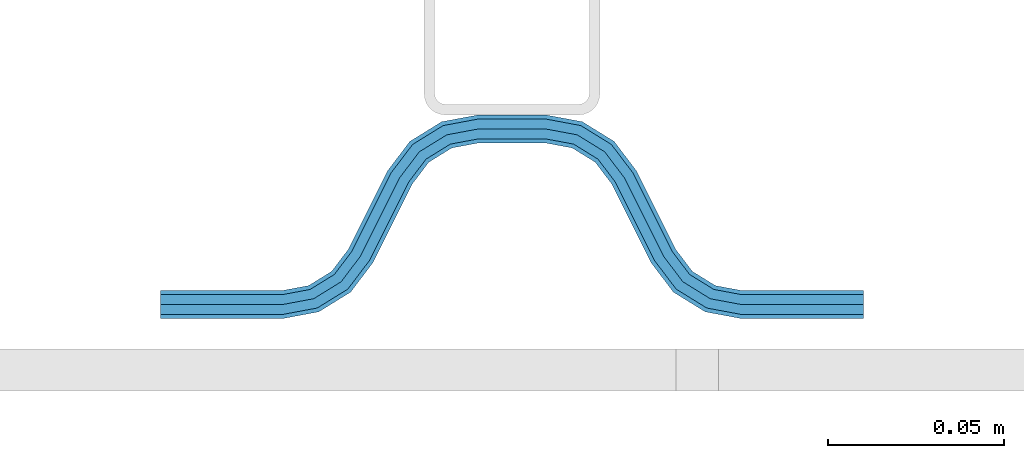
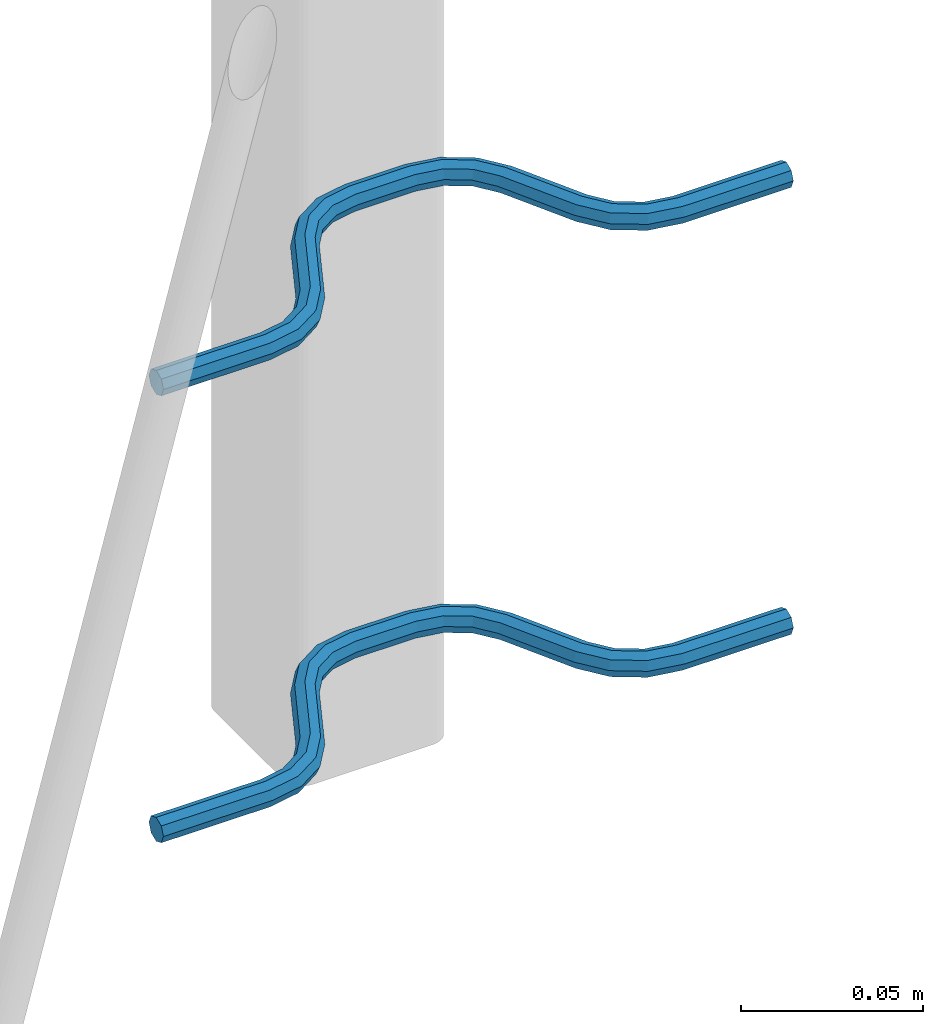
# One storey, part 4 of 5: 2 beams, 2 elements without a shape of their own.
"""IFC2X3 building model written with IfcOpenShell, lengths in millimetres."""

from ifc_helpers import new_model, si_unit, frame, origin_with_axes, place, context, subcontext, project, spatial, faceted_brep, material, type_object, element, aggregate, save


model = new_model("IFC2X3")

# Units and contexts
model_context = context("Model", 3, precision=1e-05, world=origin_with_axes())
body_context = subcontext(model_context, "Body", "Model", "MODEL_VIEW")
ifc_project = project(units=[si_unit("LENGTHUNIT", "METRE", prefix="MILLI"), si_unit("AREAUNIT", "SQUARE_METRE"), si_unit("VOLUMEUNIT", "CUBIC_METRE"), si_unit("MASSUNIT", "GRAM", prefix="KILO"), si_unit("TIMEUNIT", "SECOND"), si_unit("PLANEANGLEUNIT", "RADIAN"), si_unit("SOLIDANGLEUNIT", "STERADIAN"), si_unit("THERMODYNAMICTEMPERATUREUNIT", "DEGREE_CELSIUS"), si_unit("LUMINOUSINTENSITYUNIT", "LUMEN")], contexts=[model_context])

# Site, building, storey
site_placement = place(None, origin_with_axes())
site = spatial("IfcSite", under=ifc_project, at=site_placement, CompositionType="ELEMENT")
building_placement = place(site_placement, origin_with_axes())
building = spatial("IfcBuilding", under=site, at=building_placement, Name="Undefined", CompositionType="ELEMENT")
storey_placement = place(building_placement, origin_with_axes())
storey = spatial("IfcBuildingStorey", under=building, at=storey_placement, Name="Undefined", CompositionType="ELEMENT", Elevation=0.0)

# Assembly, beam
assembly_1_placement = place(storey_placement, origin_with_axes())
assembly_1 = element("IfcElementAssembly", 1, at=assembly_1_placement, inside=storey, Name="Steel Assembly", AssemblyPlace="NOTDEFINED", PredefinedType="NOTDEFINED")
ifc_material = material(Name="REBAR/A500HW")
beam_type = type_object("IfcBeamType", Name="D8", PredefinedType="NOTDEFINED")
beam_1_placement = place(assembly_1_placement, frame((36820.0028955971, 6595.97468822386, 2430.99992151562), z_axis=(0.0, 0.0, 1.0), x_axis=(-0.999999999544916, 3.01689999841786e-05, 0.0)))
beam_1 = element("IfcBeam", 2, at=beam_1_placement, type_object=beam_type, material=ifc_material, Name="AnchorRebar", ObjectType="D8", context=body_context, shape_type="Brep", body=[
    faceted_brep([(2.18278728425503e-11, -4.0, 0.0), (1.45519152283669e-11, -2.82842712474576, -2.82842712474621), (34.5491497807598, -2.82842712464117, -2.82842712474621), (34.5491497803741, -3.99999999989996, 0.0), (7.27595761418343e-12, 9.09494701772928e-13, -4.0), (34.5491497807452, 1.04591890703887e-10, -4.0), (-7.27595761418343e-12, 2.82842712474667, -2.82842712474621), (34.5491497807379, 2.82842712485035, -2.82842712474621), (-1.45519152283669e-11, 4.00000000000091, 0.0), (34.5491497807307, 4.00000000010459, 0.0), (-7.27595761418343e-12, 2.82842712474667, 2.82842712474621), (34.5491497807379, 2.82842712485035, 2.82842712474621), (7.27595761418343e-12, 9.09494701772928e-13, 4.0), (34.5491497807452, 1.04591890703887e-10, 4.0), (1.45519152283669e-11, -2.82842712474576, 2.82842712474621), (34.5491497807598, -2.82842712464117, 2.82842712474621), (45.0102956729461, 2.04744769146328, 0.0), (44.5876751635806, 0.954756103187719, -2.82842712474621), (43.5673789981374, -1.68323474873705, -4.0), (42.5470828327016, -4.32122560064909, -2.82842712474621), (42.1244623233288, -5.41391718892919, 0.0), (42.5470828327016, -4.32122560064909, 2.82842712474621), (43.5673789981374, -1.68323474873705, 4.0), (44.5876751635806, 0.954756103187719, 2.82842712474621), (53.2744249666721, -4.41395070840099, 2.82842712474621), (54.0627564232709, -3.54728092319965, 0.0), (51.3712244725102, -6.5062766579249, 4.0), (49.4680239783702, -8.5986026074479, 2.82842712474621), (48.6796925217786, -9.46527239263742, 0.0), (49.4680239783702, -8.5986026074479, -2.82842712474621), (51.3712244725102, -6.5062766579249, -4.0), (53.2744249666721, -4.41395070840099, -2.82842712474621), (59.4396520595255, -12.5547498008955, 2.82842712474621), (60.4875387112043, -12.0308065146473, 0.0), (56.9098298931422, -13.8196607884638, 4.0), (54.3800077267733, -15.0845717760394, 2.82842712474621), (53.3321210758877, -15.6085150625322, 0.0), (54.3800077267733, -15.0845717760394, -2.82842712474621), (56.9098298931422, -13.8196607884638, -4.0), (59.4396520595255, -12.5547498008955, -2.82842712474621), (65.5603461600695, -37.4452503321118, -2.82842712474621), (64.5124595074303, -37.9691936178024, 0.0), (68.0901683264674, -36.1803393445653, -4.0), (70.6199904928581, -34.9154283570169, -2.82842712474621), (71.6678771445659, -34.3914850707815, 0.0), (70.6199904928581, -34.9154283570169, 2.82842712474621), (68.0901683264674, -36.1803393445653, 4.0), (65.5603461600695, -37.4452503321118, 2.82842712474621), (76.3203054721744, -40.5347275358363, 0.0), (75.53197400301, -41.4013973095998, -2.82842712474621), (73.6287734785365, -43.4937232315178, -4.0), (71.7255729540339, -45.5860491534368, -2.82842712474621), (70.9372414848622, -46.4527189272021, 0.0), (71.7255729540339, -45.5860491534368, 2.82842712474621), (73.6287734785365, -43.4937232315178, 4.0), (75.53197400301, -41.4013973095998, 2.82842712474621), (82.4529147876528, -45.6787743011646, 2.82842712474621), (82.8755353286688, -44.5860827251363, 0.0), (81.4326185457539, -48.3167651235117, 4.0), (80.4123223038914, -50.9547559458606, 2.82842712474621), (79.9897017628609, -52.0474475218944, 0.0), (80.4123223038914, -50.9547559458606, -2.82842712474621), (81.4326185457539, -48.3167651235117, -4.0), (82.4529147876528, -45.6787743011646, -2.82842712474621), (90.4508474762042, -47.1715730090009, 2.82842712474621), (90.450847527085, -46.0000001337467, 0.0), (90.4508473533715, -50.0000001337448, 4.0), (90.4508472305388, -52.8284272584888, 2.82842712474621), (90.4508471810695, -54.0000001334174, 0.0), (90.4508472305388, -52.8284272584888, -2.82842712474621), (90.4508473533715, -50.0000001337448, -4.0), (90.4508474762042, -47.1715730090009, -2.82842712474621), (109.549147671336, -52.8284280870112, -2.82842712474621), (109.549147618905, -54.0000009615069, 0.0), (109.549147794081, -50.0000009622636, -4.0), (109.549147916834, -47.1715738375178, -2.82842712474621), (109.549147967678, -46.0000009622645, 0.0), (109.549147916834, -47.1715738375178, 2.82842712474621), (109.549147794081, -50.0000009622636, 4.0), (109.549147671336, -52.8284280870112, 2.82842712474621), (120.010293517997, -52.0474491371906, 0.0), (119.587673059228, -50.9547575293454, 2.82842712474621), (118.567377015977, -48.3167666302043, 4.0), (117.547080972698, -45.6787757310603, 2.82842712474621), (117.124460513915, -44.5860841232243, 0.0), (117.547080972698, -45.6787757310603, -2.82842712474621), (118.567377015977, -48.3167666302043, -4.0), (119.587673059228, -50.9547575293454, -2.82842712474621), (128.274423051233, -45.586051174274, -2.82842712474621), (129.062754465187, -46.4527209982516, 0.0), (126.371222660055, -43.4937251311139, -4.0), (124.468022268862, -41.4013990879685, -2.82842712474621), (123.679690854915, -40.5347292639935, 0.0), (124.468022268862, -41.4013990879685, 2.82842712474621), (126.371222660055, -43.4937251311139, 4.0), (128.274423051233, -45.586051174274, 2.82842712474621), (134.439650508568, -37.4452524573453, -2.82842712474621), (135.48753713489, -37.9691957980858, 0.0), (131.909828408126, -36.1803413379666, -4.0), (129.380006307663, -34.9154302185971, -2.82842712474621), (128.332119683255, -34.3914868777574, 0.0), (129.380006307663, -34.9154302185971, 2.82842712474621), (131.909828408126, -36.1803413379666, 4.0), (134.439650508568, -37.4452524573453, 2.82842712474621), (145.619991978041, -15.0845707426524, -2.82842712474621), (146.66787860055, -15.6085140834621, 0.0), (143.09016987752, -13.8196596233502, -4.0), (140.560347777006, -12.5547485040488, -2.82842712474621), (139.512461152583, -12.0308051632373, 0.0), (140.560347777006, -12.5547485040488, 2.82842712474621), (143.09016987752, -13.8196596233502, 4.0), (145.619991978041, -15.0845707426524, 2.82842712474621), (151.32030720418, -9.46527190098914, 0.0), (150.531975777645, -8.59860208845657, 2.82842712474621), (148.628775356075, -6.50627607293518, 4.0), (146.725574934491, -4.41395005741106, 2.82842712474621), (145.937243507949, -3.5472802448794, 0.0), (146.725574934491, -4.41395005741106, -2.82842712474621), (148.628775356075, -6.50627607293518, -4.0), (150.531975777645, -8.59860208845657, -2.82842712474621), (157.452916713031, -4.32122546032224, -2.82842712474621), (157.875537203472, -5.41391705590922, 0.0), (156.432620593252, -1.68323459075145, -4.0), (155.412324473487, 0.954756278815694, -2.82842712474621), (154.989703983039, 2.04744787441086, 0.0), (155.412324473487, 0.954756278815694, 2.82842712474621), (156.432620593252, -1.68323459075145, 4.0), (157.452916713031, -4.32122546032224, 2.82842712474621), (165.450849406719, -2.82842712265665, -2.82842712474621), (165.4508494084, -3.99999999905958, 0.0), (165.450849406632, 2.07910488825291e-09, -4.0), (165.45084940653, 2.82842712682032, -2.82842712474621), (165.450849406501, 4.00000000206637, 0.0), (165.45084940653, 2.82842712682032, 2.82842712474621), (165.450849406632, 2.07910488825291e-09, 4.0), (165.450849406719, -2.82842712265665, 2.82842712474621), (200.00000008905, -2.8284271237826, -2.82842712474621), (200.00000008905, -3.99999999903685, 0.0), (200.00000008905, 9.64064383879304e-10, -4.0), (200.00000008905, 2.82842712570982, -2.82842712474621), (200.00000008905, 4.00000000096315, 0.0), (200.00000008905, 2.82842712570982, 2.82842712474621), (200.00000008905, 9.64064383879304e-10, 4.0), (200.00000008905, -2.8284271237826, 2.82842712474621)], [[[0, 1, 2, 3]], [[1, 4, 5, 2]], [[4, 6, 7, 5]], [[6, 8, 9, 7]], [[8, 10, 11, 9]], [[10, 12, 13, 11]], [[12, 14, 15, 13]], [[14, 0, 3, 15]], [[14, 12, 10, 8, 6, 4, 1, 0]], [[7, 9, 16, 17]], [[5, 7, 17, 18]], [[2, 5, 18, 19]], [[3, 2, 19, 20]], [[15, 3, 20, 21]], [[13, 15, 21, 22]], [[11, 13, 22, 23]], [[9, 11, 23, 16]], [[23, 24, 25, 16]], [[22, 26, 24, 23]], [[21, 27, 26, 22]], [[20, 28, 27, 21]], [[19, 29, 28, 20]], [[18, 30, 29, 19]], [[17, 31, 30, 18]], [[16, 25, 31, 17]], [[24, 32, 33, 25]], [[26, 34, 32, 24]], [[27, 35, 34, 26]], [[28, 36, 35, 27]], [[29, 37, 36, 28]], [[30, 38, 37, 29]], [[31, 39, 38, 30]], [[25, 33, 39, 31]], [[36, 37, 40, 41]], [[37, 38, 42, 40]], [[38, 39, 43, 42]], [[39, 33, 44, 43]], [[33, 32, 45, 44]], [[32, 34, 46, 45]], [[34, 35, 47, 46]], [[35, 36, 41, 47]], [[43, 44, 48, 49]], [[42, 43, 49, 50]], [[40, 42, 50, 51]], [[41, 40, 51, 52]], [[47, 41, 52, 53]], [[46, 47, 53, 54]], [[45, 46, 54, 55]], [[44, 45, 55, 48]], [[55, 56, 57, 48]], [[54, 58, 56, 55]], [[53, 59, 58, 54]], [[52, 60, 59, 53]], [[51, 61, 60, 52]], [[50, 62, 61, 51]], [[49, 63, 62, 50]], [[48, 57, 63, 49]], [[56, 64, 65, 57]], [[58, 66, 64, 56]], [[59, 67, 66, 58]], [[60, 68, 67, 59]], [[61, 69, 68, 60]], [[62, 70, 69, 61]], [[63, 71, 70, 62]], [[57, 65, 71, 63]], [[68, 69, 72, 73]], [[69, 70, 74, 72]], [[70, 71, 75, 74]], [[71, 65, 76, 75]], [[65, 64, 77, 76]], [[64, 66, 78, 77]], [[66, 67, 79, 78]], [[67, 68, 73, 79]], [[79, 73, 80, 81]], [[78, 79, 81, 82]], [[77, 78, 82, 83]], [[76, 77, 83, 84]], [[75, 76, 84, 85]], [[74, 75, 85, 86]], [[72, 74, 86, 87]], [[73, 72, 87, 80]], [[87, 88, 89, 80]], [[86, 90, 88, 87]], [[85, 91, 90, 86]], [[84, 92, 91, 85]], [[83, 93, 92, 84]], [[82, 94, 93, 83]], [[81, 95, 94, 82]], [[80, 89, 95, 81]], [[88, 96, 97, 89]], [[90, 98, 96, 88]], [[91, 99, 98, 90]], [[92, 100, 99, 91]], [[93, 101, 100, 92]], [[94, 102, 101, 93]], [[95, 103, 102, 94]], [[89, 97, 103, 95]], [[97, 96, 104, 105]], [[96, 98, 106, 104]], [[98, 99, 107, 106]], [[99, 100, 108, 107]], [[100, 101, 109, 108]], [[101, 102, 110, 109]], [[102, 103, 111, 110]], [[103, 97, 105, 111]], [[111, 105, 112, 113]], [[110, 111, 113, 114]], [[109, 110, 114, 115]], [[108, 109, 115, 116]], [[107, 108, 116, 117]], [[106, 107, 117, 118]], [[104, 106, 118, 119]], [[105, 104, 119, 112]], [[119, 120, 121, 112]], [[118, 122, 120, 119]], [[117, 123, 122, 118]], [[116, 124, 123, 117]], [[115, 125, 124, 116]], [[114, 126, 125, 115]], [[113, 127, 126, 114]], [[112, 121, 127, 113]], [[120, 128, 129, 121]], [[122, 130, 128, 120]], [[123, 131, 130, 122]], [[124, 132, 131, 123]], [[125, 133, 132, 124]], [[126, 134, 133, 125]], [[127, 135, 134, 126]], [[121, 129, 135, 127]], [[129, 128, 136, 137]], [[128, 130, 138, 136]], [[130, 131, 139, 138]], [[131, 132, 140, 139]], [[132, 133, 141, 140]], [[133, 134, 142, 141]], [[134, 135, 143, 142]], [[135, 129, 137, 143]], [[138, 139, 140, 141, 142, 143, 137, 136]]]),
])
aggregate(assembly_1, [beam_1])

assembly_2_placement = place(storey_placement, origin_with_axes())
assembly_2 = element("IfcElementAssembly", 3, at=assembly_2_placement, inside=storey, Name="Steel Assembly", AssemblyPlace="NOTDEFINED", PredefinedType="NOTDEFINED")
beam_2_placement = place(assembly_2_placement, frame((36820.0028955971, 6595.97468822386, 2580.99992151562), z_axis=(0.0, 0.0, 1.0), x_axis=(-0.999999999544916, 3.01689999841786e-05, 0.0)))
beam_2 = element("IfcBeam", 4, at=beam_2_placement, type_object=beam_type, material=ifc_material, Name="AnchorRebar", ObjectType="D8", context=body_context, shape_type="Brep", body=[
    faceted_brep([(2.18278728425503e-11, -4.0, 0.0), (1.45519152283669e-11, -2.82842712474576, -2.82842712474621), (34.5491497807598, -2.82842712464117, -2.82842712474621), (34.5491497803741, -3.99999999989996, 0.0), (7.27595761418343e-12, 9.09494701772928e-13, -4.0), (34.5491497807452, 1.04591890703887e-10, -4.0), (-7.27595761418343e-12, 2.82842712474667, -2.82842712474621), (34.5491497807379, 2.82842712485035, -2.82842712474621), (-1.45519152283669e-11, 4.00000000000091, 0.0), (34.5491497807307, 4.00000000010459, 0.0), (-7.27595761418343e-12, 2.82842712474667, 2.82842712474621), (34.5491497807379, 2.82842712485035, 2.82842712474621), (7.27595761418343e-12, 9.09494701772928e-13, 4.0), (34.5491497807452, 1.04591890703887e-10, 4.0), (1.45519152283669e-11, -2.82842712474576, 2.82842712474621), (34.5491497807598, -2.82842712464117, 2.82842712474621), (45.0102956729461, 2.04744769146328, 0.0), (44.5876751635806, 0.954756103187719, -2.82842712474621), (43.5673789981374, -1.68323474873705, -4.0), (42.5470828327016, -4.32122560064909, -2.82842712474621), (42.1244623233288, -5.41391718892919, 0.0), (42.5470828327016, -4.32122560064909, 2.82842712474621), (43.5673789981374, -1.68323474873705, 4.0), (44.5876751635806, 0.954756103187719, 2.82842712474621), (53.2744249666721, -4.41395070840099, 2.82842712474621), (54.0627564232709, -3.54728092319965, 0.0), (51.3712244725102, -6.5062766579249, 4.0), (49.4680239783702, -8.5986026074479, 2.82842712474621), (48.6796925217786, -9.46527239263742, 0.0), (49.4680239783702, -8.5986026074479, -2.82842712474621), (51.3712244725102, -6.5062766579249, -4.0), (53.2744249666721, -4.41395070840099, -2.82842712474621), (59.4396520595255, -12.5547498008955, 2.82842712474621), (60.4875387112043, -12.0308065146473, 0.0), (56.9098298931422, -13.8196607884638, 4.0), (54.3800077267733, -15.0845717760394, 2.82842712474621), (53.3321210758877, -15.6085150625322, 0.0), (54.3800077267733, -15.0845717760394, -2.82842712474621), (56.9098298931422, -13.8196607884638, -4.0), (59.4396520595255, -12.5547498008955, -2.82842712474621), (65.5603461600695, -37.4452503321118, -2.82842712474621), (64.5124595074303, -37.9691936178024, 0.0), (68.0901683264674, -36.1803393445653, -4.0), (70.6199904928581, -34.9154283570169, -2.82842712474621), (71.6678771445659, -34.3914850707815, 0.0), (70.6199904928581, -34.9154283570169, 2.82842712474621), (68.0901683264674, -36.1803393445653, 4.0), (65.5603461600695, -37.4452503321118, 2.82842712474621), (76.3203054721744, -40.5347275358363, 0.0), (75.53197400301, -41.4013973095998, -2.82842712474621), (73.6287734785365, -43.4937232315178, -4.0), (71.7255729540339, -45.5860491534368, -2.82842712474621), (70.9372414848622, -46.4527189272021, 0.0), (71.7255729540339, -45.5860491534368, 2.82842712474621), (73.6287734785365, -43.4937232315178, 4.0), (75.53197400301, -41.4013973095998, 2.82842712474621), (82.4529147876528, -45.6787743011646, 2.82842712474621), (82.8755353286688, -44.5860827251363, 0.0), (81.4326185457539, -48.3167651235117, 4.0), (80.4123223038914, -50.9547559458606, 2.82842712474621), (79.9897017628609, -52.0474475218944, 0.0), (80.4123223038914, -50.9547559458606, -2.82842712474621), (81.4326185457539, -48.3167651235117, -4.0), (82.4529147876528, -45.6787743011646, -2.82842712474621), (90.4508474762042, -47.1715730090009, 2.82842712474621), (90.450847527085, -46.0000001337467, 0.0), (90.4508473533715, -50.0000001337448, 4.0), (90.4508472305388, -52.8284272584888, 2.82842712474621), (90.4508471810695, -54.0000001334174, 0.0), (90.4508472305388, -52.8284272584888, -2.82842712474621), (90.4508473533715, -50.0000001337448, -4.0), (90.4508474762042, -47.1715730090009, -2.82842712474621), (109.549147671336, -52.8284280870112, -2.82842712474621), (109.549147618905, -54.0000009615069, 0.0), (109.549147794081, -50.0000009622636, -4.0), (109.549147916834, -47.1715738375178, -2.82842712474621), (109.549147967678, -46.0000009622645, 0.0), (109.549147916834, -47.1715738375178, 2.82842712474621), (109.549147794081, -50.0000009622636, 4.0), (109.549147671336, -52.8284280870112, 2.82842712474621), (120.010293517997, -52.0474491371906, 0.0), (119.587673059228, -50.9547575293454, 2.82842712474621), (118.567377015977, -48.3167666302043, 4.0), (117.547080972698, -45.6787757310603, 2.82842712474621), (117.124460513915, -44.5860841232243, 0.0), (117.547080972698, -45.6787757310603, -2.82842712474621), (118.567377015977, -48.3167666302043, -4.0), (119.587673059228, -50.9547575293454, -2.82842712474621), (128.274423051233, -45.586051174274, -2.82842712474621), (129.062754465187, -46.4527209982516, 0.0), (126.371222660055, -43.4937251311139, -4.0), (124.468022268862, -41.4013990879685, -2.82842712474621), (123.679690854915, -40.5347292639935, 0.0), (124.468022268862, -41.4013990879685, 2.82842712474621), (126.371222660055, -43.4937251311139, 4.0), (128.274423051233, -45.586051174274, 2.82842712474621), (134.439650508568, -37.4452524573453, -2.82842712474621), (135.48753713489, -37.9691957980858, 0.0), (131.909828408126, -36.1803413379666, -4.0), (129.380006307663, -34.9154302185971, -2.82842712474621), (128.332119683255, -34.3914868777574, 0.0), (129.380006307663, -34.9154302185971, 2.82842712474621), (131.909828408126, -36.1803413379666, 4.0), (134.439650508568, -37.4452524573453, 2.82842712474621), (145.619991978041, -15.0845707426524, -2.82842712474621), (146.66787860055, -15.6085140834621, 0.0), (143.09016987752, -13.8196596233502, -4.0), (140.560347777006, -12.5547485040488, -2.82842712474621), (139.512461152583, -12.0308051632373, 0.0), (140.560347777006, -12.5547485040488, 2.82842712474621), (143.09016987752, -13.8196596233502, 4.0), (145.619991978041, -15.0845707426524, 2.82842712474621), (151.32030720418, -9.46527190098914, 0.0), (150.531975777645, -8.59860208845657, 2.82842712474621), (148.628775356075, -6.50627607293518, 4.0), (146.725574934491, -4.41395005741106, 2.82842712474621), (145.937243507949, -3.5472802448794, 0.0), (146.725574934491, -4.41395005741106, -2.82842712474621), (148.628775356075, -6.50627607293518, -4.0), (150.531975777645, -8.59860208845657, -2.82842712474621), (157.452916713031, -4.32122546032224, -2.82842712474621), (157.875537203472, -5.41391705590922, 0.0), (156.432620593252, -1.68323459075145, -4.0), (155.412324473487, 0.954756278815694, -2.82842712474621), (154.989703983039, 2.04744787441086, 0.0), (155.412324473487, 0.954756278815694, 2.82842712474621), (156.432620593252, -1.68323459075145, 4.0), (157.452916713031, -4.32122546032224, 2.82842712474621), (165.450849406719, -2.82842712265665, -2.82842712474621), (165.4508494084, -3.99999999905958, 0.0), (165.450849406632, 2.07910488825291e-09, -4.0), (165.45084940653, 2.82842712682032, -2.82842712474621), (165.450849406501, 4.00000000206637, 0.0), (165.45084940653, 2.82842712682032, 2.82842712474621), (165.450849406632, 2.07910488825291e-09, 4.0), (165.450849406719, -2.82842712265665, 2.82842712474621), (200.00000008905, -2.8284271237826, -2.82842712474621), (200.00000008905, -3.99999999903685, 0.0), (200.00000008905, 9.64064383879304e-10, -4.0), (200.00000008905, 2.82842712570982, -2.82842712474621), (200.00000008905, 4.00000000096315, 0.0), (200.00000008905, 2.82842712570982, 2.82842712474621), (200.00000008905, 9.64064383879304e-10, 4.0), (200.00000008905, -2.8284271237826, 2.82842712474621)], [[[0, 1, 2, 3]], [[1, 4, 5, 2]], [[4, 6, 7, 5]], [[6, 8, 9, 7]], [[8, 10, 11, 9]], [[10, 12, 13, 11]], [[12, 14, 15, 13]], [[14, 0, 3, 15]], [[14, 12, 10, 8, 6, 4, 1, 0]], [[7, 9, 16, 17]], [[5, 7, 17, 18]], [[2, 5, 18, 19]], [[3, 2, 19, 20]], [[15, 3, 20, 21]], [[13, 15, 21, 22]], [[11, 13, 22, 23]], [[9, 11, 23, 16]], [[23, 24, 25, 16]], [[22, 26, 24, 23]], [[21, 27, 26, 22]], [[20, 28, 27, 21]], [[19, 29, 28, 20]], [[18, 30, 29, 19]], [[17, 31, 30, 18]], [[16, 25, 31, 17]], [[24, 32, 33, 25]], [[26, 34, 32, 24]], [[27, 35, 34, 26]], [[28, 36, 35, 27]], [[29, 37, 36, 28]], [[30, 38, 37, 29]], [[31, 39, 38, 30]], [[25, 33, 39, 31]], [[36, 37, 40, 41]], [[37, 38, 42, 40]], [[38, 39, 43, 42]], [[39, 33, 44, 43]], [[33, 32, 45, 44]], [[32, 34, 46, 45]], [[34, 35, 47, 46]], [[35, 36, 41, 47]], [[43, 44, 48, 49]], [[42, 43, 49, 50]], [[40, 42, 50, 51]], [[41, 40, 51, 52]], [[47, 41, 52, 53]], [[46, 47, 53, 54]], [[45, 46, 54, 55]], [[44, 45, 55, 48]], [[55, 56, 57, 48]], [[54, 58, 56, 55]], [[53, 59, 58, 54]], [[52, 60, 59, 53]], [[51, 61, 60, 52]], [[50, 62, 61, 51]], [[49, 63, 62, 50]], [[48, 57, 63, 49]], [[56, 64, 65, 57]], [[58, 66, 64, 56]], [[59, 67, 66, 58]], [[60, 68, 67, 59]], [[61, 69, 68, 60]], [[62, 70, 69, 61]], [[63, 71, 70, 62]], [[57, 65, 71, 63]], [[68, 69, 72, 73]], [[69, 70, 74, 72]], [[70, 71, 75, 74]], [[71, 65, 76, 75]], [[65, 64, 77, 76]], [[64, 66, 78, 77]], [[66, 67, 79, 78]], [[67, 68, 73, 79]], [[79, 73, 80, 81]], [[78, 79, 81, 82]], [[77, 78, 82, 83]], [[76, 77, 83, 84]], [[75, 76, 84, 85]], [[74, 75, 85, 86]], [[72, 74, 86, 87]], [[73, 72, 87, 80]], [[87, 88, 89, 80]], [[86, 90, 88, 87]], [[85, 91, 90, 86]], [[84, 92, 91, 85]], [[83, 93, 92, 84]], [[82, 94, 93, 83]], [[81, 95, 94, 82]], [[80, 89, 95, 81]], [[88, 96, 97, 89]], [[90, 98, 96, 88]], [[91, 99, 98, 90]], [[92, 100, 99, 91]], [[93, 101, 100, 92]], [[94, 102, 101, 93]], [[95, 103, 102, 94]], [[89, 97, 103, 95]], [[97, 96, 104, 105]], [[96, 98, 106, 104]], [[98, 99, 107, 106]], [[99, 100, 108, 107]], [[100, 101, 109, 108]], [[101, 102, 110, 109]], [[102, 103, 111, 110]], [[103, 97, 105, 111]], [[111, 105, 112, 113]], [[110, 111, 113, 114]], [[109, 110, 114, 115]], [[108, 109, 115, 116]], [[107, 108, 116, 117]], [[106, 107, 117, 118]], [[104, 106, 118, 119]], [[105, 104, 119, 112]], [[119, 120, 121, 112]], [[118, 122, 120, 119]], [[117, 123, 122, 118]], [[116, 124, 123, 117]], [[115, 125, 124, 116]], [[114, 126, 125, 115]], [[113, 127, 126, 114]], [[112, 121, 127, 113]], [[120, 128, 129, 121]], [[122, 130, 128, 120]], [[123, 131, 130, 122]], [[124, 132, 131, 123]], [[125, 133, 132, 124]], [[126, 134, 133, 125]], [[127, 135, 134, 126]], [[121, 129, 135, 127]], [[129, 128, 136, 137]], [[128, 130, 138, 136]], [[130, 131, 139, 138]], [[131, 132, 140, 139]], [[132, 133, 141, 140]], [[133, 134, 142, 141]], [[134, 135, 143, 142]], [[135, 129, 137, 143]], [[138, 139, 140, 141, 142, 143, 137, 136]]]),
])
aggregate(assembly_2, [beam_2])

save(model, "model.ifc")
